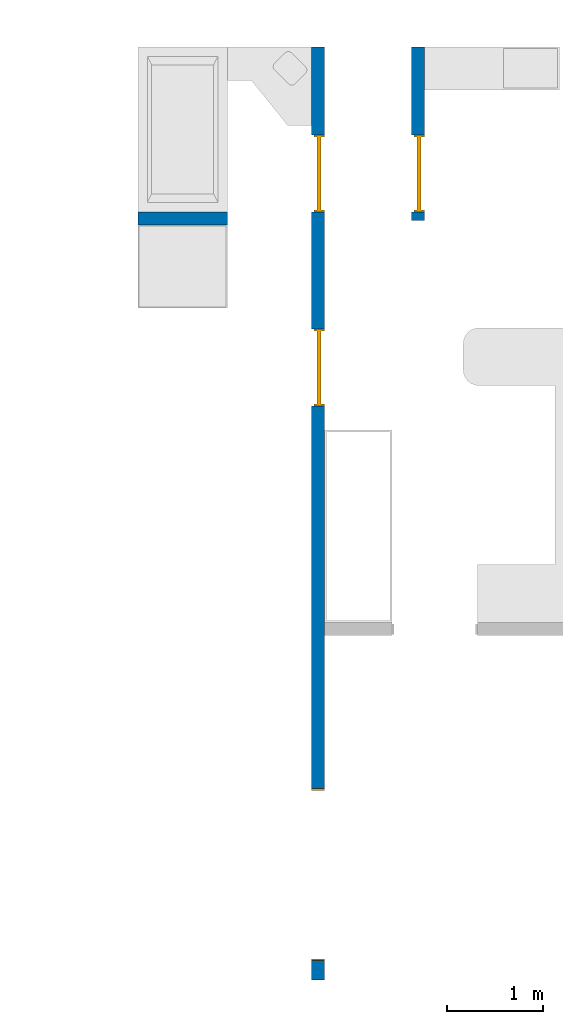
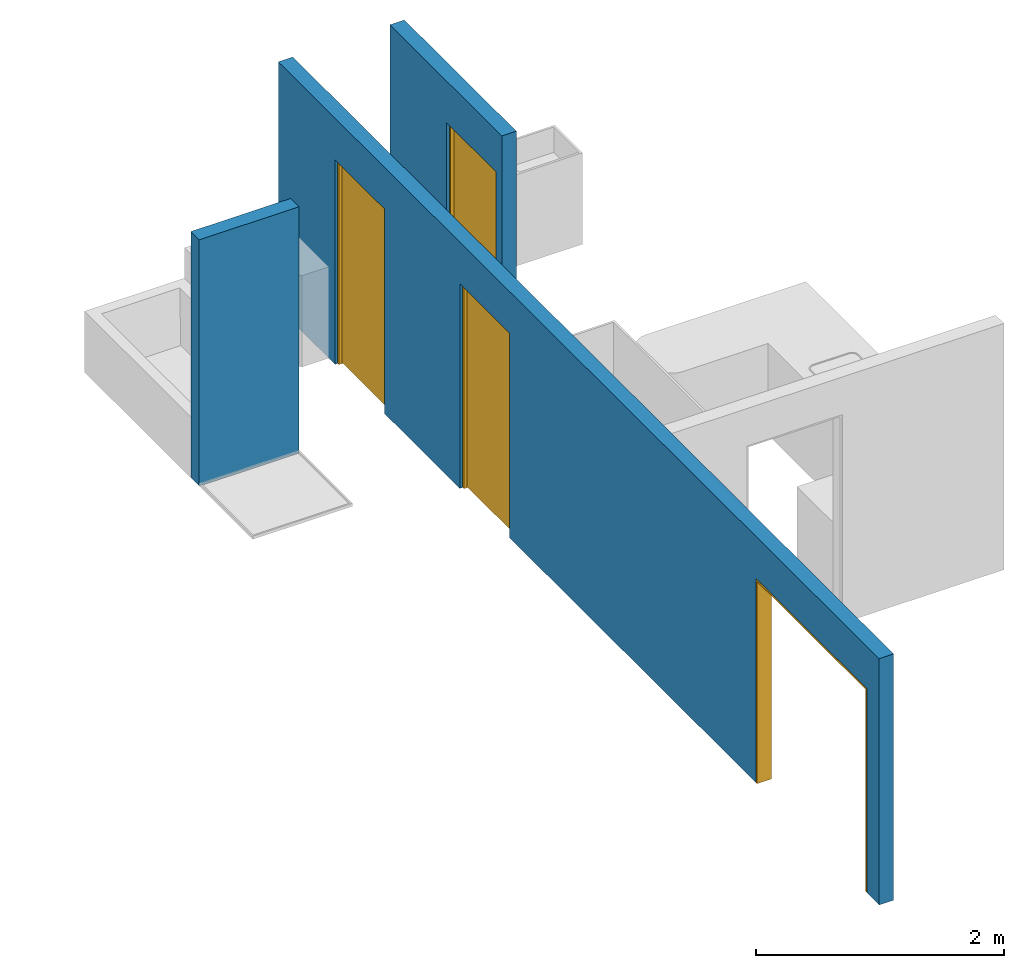
# One storey, part 2 of 6: 4 doors, 3 walls, 4 openings.
"""IFC4 building model written with IfcOpenShell, lengths in millimetres."""

import ifcopenshell
import ifcopenshell.guid

model = None  # the IFC model being written
_history = None  # IfcOwnerHistory: only IFC2X3 demands one
_inside = {}  # id of a spatial element -> (the spatial element, [elements in it])
_under = {}  # id of a project, library or spatial element -> (it, [spatial elements below it])
_declared = {}  # id of a project -> (the project, [libraries it declares])
_typed = {}  # id of a type object -> (the type object, [elements of that type])
_made_of = {}  # id of a material, layer set ... -> (it, [elements and type objects made of it])


def new_model(schema):
    """Start an empty IFC model of exactly this schema.

    Asked for "IFC4X3", IfcOpenShell would pick the latest addendum, in which some entities
    have other attributes; the version numbers below select the first issue.
    IFC2X3 requires an IfcOwnerHistory on every rooted entity: one is made here for all.
    """
    global model, _history
    if schema == "IFC4X3":
        model = ifcopenshell.file(schema_version=(4, 3, 0, 0))
    else:
        model = ifcopenshell.file(schema=schema)
    _inside.clear()
    _under.clear()
    _declared.clear()
    _typed.clear()
    _made_of.clear()
    _history = None
    if model.schema == "IFC2X3":
        org = make("IfcOrganization", Name="unknown")
        user = make(
            "IfcPersonAndOrganization",
            ThePerson=make("IfcPerson", FamilyName="unknown"),
            TheOrganization=org,
        )
        app = make(
            "IfcApplication",
            ApplicationDeveloper=org,
            Version="unknown",
            ApplicationFullName="unknown",
            ApplicationIdentifier="unknown",
        )
        _history = make(
            "IfcOwnerHistory",
            OwningUser=user,
            OwningApplication=app,
            ChangeAction="ADDED",
            CreationDate=0,
        )
    return model


def make(cls, **values):
    """One entity of the class cls with the attributes given. An attribute that is None is left unset."""
    return model.create_entity(
        cls, **{name: value for name, value in values.items() if value is not None}
    )


def entity(cls, *values):
    """Any entity or typed value of the class cls, its attributes in the order of the schema. None: left unset."""
    e = model.create_entity(cls)
    for i, value in enumerate(values):
        if value is not None:
            e[i] = value
    return e


def rooted(cls, **values):
    """An entity with a GlobalId (a new one), such as an element, a storey or a relation."""
    return make(cls, GlobalId=ifcopenshell.guid.new(), OwnerHistory=_history, **values)


def si_unit(unit_type, name, prefix=None):
    """IfcSIUnit, for example si_unit("LENGTHUNIT", "METRE", prefix="MILLI")."""
    return make("IfcSIUnit", UnitType=unit_type, Prefix=prefix, Name=name)


def converted_unit(unit_type, name, factor, base, dimensions=None, offset=None):
    """IfcConversionBasedUnit, such as the inch: factor (a typed value) times the base unit."""
    return make(
        "IfcConversionBasedUnit"
        if offset is None
        else "IfcConversionBasedUnitWithOffset",
        ConversionOffset=offset,
        Dimensions=None
        if dimensions is None
        else entity("IfcDimensionalExponents", *dimensions),
        UnitType=unit_type,
        Name=name,
        ConversionFactor=make(
            "IfcMeasureWithUnit", ValueComponent=factor, UnitComponent=base
        ),
    )


def assignment(units):
    """IfcUnitAssignment: the units of a project."""
    return None if units is None else make("IfcUnitAssignment", Units=units)


def point(xyz):
    """IfcCartesianPoint."""
    return None if xyz is None else make("IfcCartesianPoint", Coordinates=xyz)


def direction(xyz):
    """IfcDirection."""
    return None if xyz is None else make("IfcDirection", DirectionRatios=xyz)


def frame(location, z_axis=None, x_axis=None):
    """IfcAxis2Placement3D, a coordinate frame: its origin and axes. An axis left out is left unset."""
    return make(
        "IfcAxis2Placement3D",
        Location=point(location),
        Axis=direction(z_axis),
        RefDirection=direction(x_axis),
    )


def frame_2d(location, x_axis=None):
    """IfcAxis2Placement2D, a coordinate frame in the plane: its origin and x axis."""
    return make(
        "IfcAxis2Placement2D", Location=point(location), RefDirection=direction(x_axis)
    )


def origin_with_axes():
    """The frame at (0, 0, 0) with the z axis (0, 0, 1) and the x axis (1, 0, 0) written out."""
    return frame((0.0, 0.0, 0.0), z_axis=(0.0, 0.0, 1.0), x_axis=(1.0, 0.0, 0.0))


def origin_2d_with_axis():
    """The frame at (0, 0) in the plane with the x axis (1, 0) written out."""
    return frame_2d((0.0, 0.0), x_axis=(1.0, 0.0))


def place(relative_to, where):
    """IfcLocalPlacement: puts the frame where relative to a parent placement (None: the world)."""
    return make(
        "IfcLocalPlacement", PlacementRelTo=relative_to, RelativePlacement=where
    )


def context(
    kind, dimensions, precision=None, world=None, true_north=None, identifier=None
):
    """IfcGeometricRepresentationContext, for example the 3D "Model" context."""
    return make(
        "IfcGeometricRepresentationContext",
        ContextIdentifier=identifier,
        ContextType=kind,
        CoordinateSpaceDimension=dimensions,
        Precision=precision,
        WorldCoordinateSystem=world,
        TrueNorth=true_north,
    )


def subcontext(parent, identifier, kind, view, scale=None):
    """IfcGeometricRepresentationSubContext, for example "Body" below "Model"."""
    return make(
        "IfcGeometricRepresentationSubContext",
        ContextIdentifier=identifier,
        ContextType=kind,
        ParentContext=parent,
        TargetScale=scale,
        TargetView=view,
    )


def project(units=None, contexts=None):
    """IfcProject with its units and contexts."""
    return rooted(
        "IfcProject",
        Name="project",
        RepresentationContexts=contexts,
        UnitsInContext=assignment(units),
    )


def spatial(cls, under=None, at=None, **own):
    """A site, building, storey or space (cls), placed at a placement, below another one or the project."""
    s = rooted(cls, ObjectPlacement=at, **own)
    if under is not None:
        _under.setdefault(under.id(), (under, []))[1].append(s)
    return s


def point_list(points):
    """IfcCartesianPointList2D or 3D."""
    cls = (
        "IfcCartesianPointList2D" if len(points[0]) == 2 else "IfcCartesianPointList3D"
    )
    return make(cls, CoordList=points)


def line(*indices):
    """IfcLineIndex: a straight run through numbered points of an indexed curve."""
    return model.create_entity("IfcLineIndex", indices)


def indexed_curve(points, segments=None, self_intersect=None):
    """IfcIndexedPolyCurve: lines and arcs through numbered points (the first is 1)."""
    return make(
        "IfcIndexedPolyCurve",
        Points=point_list(points),
        Segments=segments,
        SelfIntersect=self_intersect,
    )


def outline(outer, holes=None, kind="AREA"):
    """IfcArbitraryClosedProfileDef: a profile drawn as a closed curve; with holes, ...WithVoids."""
    if holes is None:
        return make("IfcArbitraryClosedProfileDef", ProfileType=kind, OuterCurve=outer)
    return make(
        "IfcArbitraryProfileDefWithVoids",
        ProfileType=kind,
        OuterCurve=outer,
        InnerCurves=holes,
    )


def extrude(swept, where, along, depth):
    """IfcExtrudedAreaSolid: the profile swept, set in the frame where, extruded along a direction by depth."""
    return make(
        "IfcExtrudedAreaSolid",
        SweptArea=swept,
        Position=where,
        ExtrudedDirection=direction(along),
        Depth=depth,
    )


def polygons(points, faces, closed=None, point_numbers=None):
    """IfcPolygonalFaceSet: a face is its outer loop, then its inner loops; points numbered from 1."""
    made = []
    for loops in faces:
        if len(loops) == 1:
            made.append(make("IfcIndexedPolygonalFace", CoordIndex=loops[0]))
        else:
            made.append(
                make(
                    "IfcIndexedPolygonalFaceWithVoids",
                    CoordIndex=loops[0],
                    InnerCoordIndices=loops[1:],
                )
            )
    return make(
        "IfcPolygonalFaceSet",
        Coordinates=point_list(points),
        Closed=closed,
        Faces=made,
        PnIndex=point_numbers,
    )


def shape(context_of_items, identifier, shape_type, items):
    """IfcShapeRepresentation: the items that make up one representation, for example the "Body"."""
    return make(
        "IfcShapeRepresentation",
        ContextOfItems=context_of_items,
        RepresentationIdentifier=identifier,
        RepresentationType=shape_type,
        Items=items,
    )


def source(mapping_origin, context_of_items, identifier, shape_type, items):
    """IfcRepresentationMap: a shape defined once, which mapped items show again and again."""
    return make(
        "IfcRepresentationMap",
        MappingOrigin=mapping_origin,
        MappedRepresentation=shape(context_of_items, identifier, shape_type, items),
    )


def transform(
    local_origin,
    x_axis=None,
    y_axis=None,
    z_axis=None,
    scale=None,
    scale2=None,
    scale3=None,
    uniform=True,
):
    """IfcCartesianTransformationOperator3D, or its non-uniform kind. x_axis, y_axis, z_axis: its Axis1, 2, 3."""
    if uniform:
        return make(
            "IfcCartesianTransformationOperator3D",
            Axis1=direction(x_axis),
            Axis2=direction(y_axis),
            LocalOrigin=point(local_origin),
            Scale=scale,
            Axis3=direction(z_axis),
        )
    return make(
        "IfcCartesianTransformationOperator3DnonUniform",
        Axis1=direction(x_axis),
        Axis2=direction(y_axis),
        LocalOrigin=point(local_origin),
        Scale=scale,
        Axis3=direction(z_axis),
        Scale2=scale2,
        Scale3=scale3,
    )


def mapped(mapping_source, mapping_target):
    """IfcMappedItem: shows the shape of a source again, moved by a transform."""
    return make(
        "IfcMappedItem", MappingSource=mapping_source, MappingTarget=mapping_target
    )


def material(Name=None, Category=None):
    """IfcMaterial."""
    return make("IfcMaterial", Name=Name, Category=Category)


def layer(
    of_material, thickness, ventilated=None, Name=None, Category=None, Priority=None
):
    """IfcMaterialLayer: one layer of a wall or slab, of a material (None: an air gap)."""
    return make(
        "IfcMaterialLayer",
        Material=of_material,
        LayerThickness=thickness,
        IsVentilated=ventilated,
        Name=Name,
        Category=Category,
        Priority=Priority,
    )


def layer_set(layers, Name=None):
    """IfcMaterialLayerSet."""
    return make("IfcMaterialLayerSet", MaterialLayers=layers, LayerSetName=Name)


def layer_usage(for_layer_set, set_direction, sense, offset, extent=None):
    """IfcMaterialLayerSetUsage: how a layer set lies in its element."""
    return make(
        "IfcMaterialLayerSetUsage",
        ForLayerSet=for_layer_set,
        LayerSetDirection=set_direction,
        DirectionSense=sense,
        OffsetFromReferenceLine=offset,
        ReferenceExtent=extent,
    )


def made_of(thing, what):
    """Note that an element or type object is made of a material, layer set ...; save() writes the relation."""
    if what is not None:
        _made_of.setdefault(what.id(), (what, []))[1].append(thing)
    return thing


def type_object(cls, material=None, **own):
    """A type object (cls), such as IfcWallType, which elements share."""
    return made_of(rooted(cls, **own), material)


def type_shapes(of_type, sources):
    """Give a type object the sources (RepresentationMaps) that its elements show as mapped items."""
    of_type.RepresentationMaps = sources


def element(
    cls,
    number,
    at=None,
    inside=None,
    cuts=None,
    type_object=None,
    material=None,
    context=None,
    identifier="Body",
    shape_type=None,
    held_by="IfcProductDefinitionShape",
    body=None,
    shapes=None,
    **own,
):
    """One element of the class cls, such as IfcWall. Its Tag is "e" and its number.

    at: its placement. inside: the storey or other place that contains it. cuts: it is an
    opening in that element (IfcRelVoidsElement). A single representation is given by context,
    identifier, shape_type and body (its items); several are given by shapes. held_by: the class
    of the entity that holds the representations. save() writes the other relations.
    """
    e = rooted(cls, Tag="e%d" % number, ObjectPlacement=at, **own)
    if body is not None:
        shapes = [shape(context, identifier, shape_type, body)]
    if shapes is not None:
        e.Representation = make(held_by, Representations=shapes)
    if inside is not None:
        _inside.setdefault(inside.id(), (inside, []))[1].append(e)
    if cuts is not None:
        rooted(
            "IfcRelVoidsElement", RelatingBuildingElement=cuts, RelatedOpeningElement=e
        )
    if type_object is not None:
        _typed.setdefault(type_object.id(), (type_object, []))[1].append(e)
    return made_of(e, material)


def fill(opening, filler):
    """IfcRelFillsElement: the door or window that sits in an opening."""
    return rooted(
        "IfcRelFillsElement",
        RelatingOpeningElement=opening,
        RelatedBuildingElement=filler,
    )


def aggregate(whole, parts):
    """IfcRelAggregates: a whole, such as a stair, and the parts it consists of."""
    return rooted("IfcRelAggregates", RelatingObject=whole, RelatedObjects=parts)


def save(model, path):
    """Write the relations noted so far, then the file.

    IfcRelAggregates (storeys below a building ...), IfcRelContainedInSpatialStructure (elements
    in a storey), IfcRelDefinesByType, IfcRelAssociatesMaterial and IfcRelDeclares: one each for
    every whole, place, type object, material and project.
    """
    for whole, parts in _under.values():
        aggregate(whole, parts)
    for where, things in _inside.values():
        rooted(
            "IfcRelContainedInSpatialStructure",
            RelatedElements=things,
            RelatingStructure=where,
        )
    for kind, things in _typed.values():
        rooted("IfcRelDefinesByType", RelatedObjects=things, RelatingType=kind)
    for what, things in _made_of.values():
        rooted("IfcRelAssociatesMaterial", RelatedObjects=things, RelatingMaterial=what)
    for by, libraries in _declared.values():
        rooted("IfcRelDeclares", RelatingContext=by, RelatedDefinitions=libraries)
    model.write(path)


model = new_model("IFC4")

# Units and contexts
model_context = context("Model", 3, precision=1e-05, world=origin_with_axes())
plan_context = context("Plan", 2, precision=1e-05, world=origin_2d_with_axis())
body_context = subcontext(model_context, "Body", "Model", "MODEL_VIEW")
ifc_project = project(units=[si_unit("VOLUMEUNIT", "CUBIC_METRE"), si_unit("LENGTHUNIT", "METRE", prefix="MILLI"), converted_unit("PLANEANGLEUNIT", "degree", entity("IfcReal", 0.0174532925199433), si_unit("PLANEANGLEUNIT", "RADIAN"), dimensions=[0, 0, 0, 0, 0, 0, 0]), si_unit("AREAUNIT", "SQUARE_METRE")], contexts=[model_context, plan_context])

# Site, building, storey
site_placement = place(None, origin_with_axes())
site = spatial("IfcSite", under=ifc_project, at=site_placement)
building_placement = place(site_placement, origin_with_axes())
building = spatial("IfcBuilding", under=site, at=building_placement, Name="Building")
storey_placement = place(building_placement, origin_with_axes())
storey = spatial("IfcBuildingStorey", under=building, at=storey_placement, Name="DEMO")

# Wall, opening, door
ifc_material = material()
ifc_layer = layer(ifc_material, 135.0)
ifc_layer_set = layer_set([ifc_layer])
ifc_layer_usage_1 = layer_usage(ifc_layer_set, "AXIS2", "POSITIVE", 0.0)
wall_type = type_object("IfcWallType", Name="WAL135", PredefinedType="NOTDEFINED", material=ifc_layer_set)
wall_1_placement = place(storey_placement, frame((11019.1202163696, 5461.66706085205, 0.0), z_axis=(0.0, 0.0, 1.0), x_axis=(3.13916473260163e-07, -0.999999999999951, 0.0)))
wall_1 = element("IfcWall", 1, at=wall_1_placement, inside=storey, type_object=wall_type, material=ifc_layer_usage_1, Name="Wall", context=body_context, shape_type="SweptSolid", body=[
    extrude(outline(indexed_curve([(0.0, 0.0), (0.0, 135.0), (1805.00031109354, 135.0), (1805.00031109354, 0.0), (0.0, 0.0)], self_intersect=False)), origin_with_axes(), (0.0, 0.0, 1.0), 2425.00019073486),
])
shared_shape_1 = source(origin_with_axes(), body_context, "Body", "SweptSolid", [
    extrude(outline(indexed_curve([(0.0, 0.0), (800.001098632812, 0.0), (800.001098632812, 2015.00024414062), (0.0, 2015.00024414062)], segments=[line(1, 2, 3, 4, 1)])), frame((-1.78813922957488e-06, -600.0, 0.0), z_axis=(0.0, -1.0, 0.0), x_axis=(1.0, 0.0, 0.0)), (0.0, 0.0, -1.0), 1200.0),
])
opening_1_placement = place(wall_1_placement, frame((915.001869201841, 0.000284435057257282, 0.0), z_axis=(0.0, 0.0, 1.0), x_axis=(1.0, 0.0, 0.0)))
opening_1 = element("IfcOpeningElement", 2, at=opening_1_placement, cuts=wall_1, Name="Opening", PredefinedType="OPENING", context=body_context, shape_type="MappedRepresentation", body=[
    mapped(shared_shape_1, transform((0.0, 0.0, 0.0), x_axis=(1.0, 0.0, 0.0), y_axis=(0.0, 1.0, 0.0), z_axis=(0.0, 0.0, 1.0), scale=1.0)),
])
door_type_1 = type_object("IfcDoorType", OperationType="NOTDEFINED", PredefinedType="DOOR")
shared_shape_2 = source(origin_with_axes(), body_context, "Body", "Tessellation", [
    polygons([(0.000119209282274824, -53.7499732971191, 0.0), (20.0005760192871, -53.7499732971191, 0.0), (0.000119209282274824, -53.75, 1994.99987792969), (20.0005760192871, -53.75, 1994.99987792969), (0.000119209282274824, 56.2500038146973, 0.0), (20.0005760192871, 56.2500076293945, 0.0), (0.000119209282274824, 56.2499351501465, 1994.99987792969), (20.0005760192871, 56.249942779541, 1994.99987792969), (799.999328613281, -53.7499656677246, 1994.99987792969), (-0.0017881392268464, -53.75, 1994.99987792969), (799.999328613281, -53.7499656677246, 2015.00024414062), (799.999328613281, 56.2499809265137, 1994.99987792969), (-0.0017881392268464, 56.2499351501465, 1994.99987792969), (799.999328613281, 56.2499809265137, 2015.00024414062), (-0.0017881392268464, 56.2499351501465, 2014.99975585938), (-0.0017881392268464, -53.75, 2014.99975585938), (779.996948242188, -53.7499656677246, 0.0), (779.996948242188, -53.7499923706055, 1994.99987792969), (799.999328613281, -53.7499656677246, 0.0), (779.996948242188, 56.2499771118164, 0.0), (779.996948242188, 56.249942779541, 1994.99987792969), (799.999328613281, 56.2499809265137, 0.0), (799.999328613281, 56.2499465942383, 1994.99987792969), (799.999328613281, -53.7499923706055, 1994.99987792969), (779.998840332031, -23.7499713897705, 1994.99987792969), (779.996948242188, -23.749942779541, 9.99998950958252), (19.9986686706543, -23.749979019165, 1994.99987792969), (779.998840332031, 16.2500343322754, 1994.99987792969), (779.996948242188, 16.2500343322754, 9.99998950958252), (19.9986686706543, 16.2500305175781, 1994.99987792969), (19.9967613220215, 16.2500305175781, 9.99998950958252), (19.9967613220215, -23.7499465942383, 9.99998950958252)], [[[1, 2, 4, 3]], [[3, 4, 8, 7]], [[7, 8, 6, 5]], [[5, 6, 2, 1]], [[3, 7, 5, 1]], [[8, 4, 2, 6]], [[10, 13, 12, 9]], [[9, 11, 16, 10]], [[12, 14, 11, 9]], [[13, 15, 14, 12]], [[15, 16, 11, 14]], [[10, 16, 15, 13]], [[18, 21, 20, 17]], [[17, 19, 24, 18]], [[20, 22, 19, 17]], [[21, 23, 22, 20]], [[23, 24, 19, 22]], [[18, 24, 23, 21]], [[26, 29, 28, 25]], [[25, 27, 32, 26]], [[28, 30, 27, 25]], [[29, 31, 30, 28]], [[31, 32, 27, 30]], [[26, 32, 31, 29]]], closed=True),
])
type_shapes(door_type_1, [shared_shape_2])
door_1_placement = place(opening_1_placement, frame((0.00145523266148473, 78.7509923562393, 0.0), z_axis=(0.0, 0.0, 1.0), x_axis=(0.999999999999886, -4.76837158203095e-07, 0.0)))
door_1 = element("IfcDoor", 3, at=door_1_placement, inside=storey, type_object=door_type_1, Name="Door", context=body_context, shape_type="MappedRepresentation", body=[
    mapped(shared_shape_2, transform((0.0, 0.0, 0.0), x_axis=(1.0, 0.0, 0.0), y_axis=(0.0, 1.0, 0.0), z_axis=(0.0, 0.0, 1.0), scale=1.0)),
])
fill(opening_1, door_1)

# Wall
ifc_layer_usage_2 = layer_usage(ifc_layer_set, "AXIS2", "POSITIVE", 0.0)
wall_2_placement = place(storey_placement, frame((8174.11994934082, 3611.6669178009, 0.0), z_axis=(0.0, 0.0, 1.0), x_axis=(0.999999999999972, 2.38418579101556e-07, 0.0)))
element("IfcWall", 4, at=wall_2_placement, inside=storey, type_object=wall_type, material=ifc_layer_usage_2, Name="Wall", context=body_context, shape_type="SweptSolid", body=[
    extrude(outline(indexed_curve([(0.0, 0.0), (0.0, 135.0), (930.000316660868, 135.0), (930.000316660868, 0.0), (0.0, 0.0)], self_intersect=False)), origin_with_axes(), (0.0, 0.0, 1.0), 2425.00019073486),
])

# Wall, openings, doors
ifc_layer_usage_3 = layer_usage(ifc_layer_set, "AXIS2", "POSITIVE", 0.0)
wall_3_placement = place(storey_placement, frame((9979.12120819092, 5461.66801452637, 0.0), z_axis=(0.0, 0.0, 1.0), x_axis=(3.13916473260163e-07, -0.999999999999951, 0.0)))
wall_3 = element("IfcWall", 5, at=wall_3_placement, inside=storey, type_object=wall_type, material=ifc_layer_usage_3, Name="Wall", context=body_context, shape_type="SweptSolid", body=[
    extrude(outline(indexed_curve([(0.0, 0.0), (0.0, 135.0), (9695.0004828675, 135.0), (9695.0004828675, 0.0), (0.0, 0.0)], self_intersect=False)), origin_with_axes(), (0.0, 0.0, 1.0), 2425.00019073486),
])
opening_2_placement = place(wall_3_placement, frame((2930.00319686536, 78.7500654126747, 0.0), z_axis=(0.0, 0.0, 1.0), x_axis=(1.0, 0.0, 0.0)))
opening_2 = element("IfcOpeningElement", 6, at=opening_2_placement, cuts=wall_3, Name="Opening", PredefinedType="OPENING", context=body_context, shape_type="MappedRepresentation", body=[
    mapped(shared_shape_1, transform((0.0, 0.0, 0.0), x_axis=(1.0, 0.0, 0.0), y_axis=(0.0, 1.0, 0.0), z_axis=(0.0, 0.0, 1.0), scale=1.0)),
])
opening_3_placement = place(wall_3_placement, frame((915.000915527553, 0.000358941234512855, 0.0), z_axis=(0.0, 0.0, 1.0), x_axis=(1.0, 0.0, 0.0)))
opening_3 = element("IfcOpeningElement", 7, at=opening_3_placement, cuts=wall_3, Name="Opening", PredefinedType="OPENING", context=body_context, shape_type="MappedRepresentation", body=[
    mapped(shared_shape_1, transform((0.0, 0.0, 0.0), x_axis=(1.0, 0.0, 0.0), y_axis=(0.0, 1.0, 0.0), z_axis=(0.0, 0.0, 1.0), scale=1.0)),
])
shared_shape_3 = source(origin_with_axes(), body_context, "Body", "SweptSolid", [
    extrude(outline(indexed_curve([(0.0, 0.0), (1790.00024414062, 0.0), (1790.00024414062, 2009.99987792969), (0.0, 2009.99987792969)], segments=[line(1, 2, 3, 4, 1)])), frame((0.0, -600.0, 0.0), z_axis=(0.0, -1.0, 0.0), x_axis=(1.0, 0.0, 0.0)), (0.0, 0.0, -1.0), 1200.0),
])
opening_4_placement = place(wall_3_placement, frame((7705.00091632267, 100.000718891784, 0.0), z_axis=(0.0, 0.0, 1.0), x_axis=(1.0, 0.0, 0.0)))
opening_4 = element("IfcOpeningElement", 8, at=opening_4_placement, cuts=wall_3, PredefinedType="OPENING", context=body_context, shape_type="MappedRepresentation", body=[
    mapped(shared_shape_3, transform((0.0, 0.0, 0.0), x_axis=(1.0, 0.0, 0.0), y_axis=(0.0, 1.0, 0.0), z_axis=(0.0, 0.0, 1.0), scale=1.0)),
])
door_2_placement = place(opening_2_placement, frame((0.00047089180021942, 0.000578836786502279, 0.0), z_axis=(0.0, 0.0, 1.0), x_axis=(0.999999999999886, -4.76837158203095e-07, 0.0)))
door_2 = element("IfcDoor", 9, at=door_2_placement, inside=storey, type_object=door_type_1, Name="Door", context=body_context, shape_type="MappedRepresentation", body=[
    mapped(shared_shape_2, transform((0.0, 0.0, 0.0), x_axis=(1.0, 0.0, 0.0), y_axis=(0.0, 1.0, 0.0), z_axis=(0.0, 0.0, 1.0), scale=1.0)),
])
fill(opening_2, door_2)
door_3_placement = place(opening_3_placement, frame((0.00145523263661573, 78.7509178503303, 0.0), z_axis=(0.0, 0.0, 1.0), x_axis=(0.999999999999886, -4.76837158203095e-07, 0.0)))
door_3 = element("IfcDoor", 10, at=door_3_placement, inside=storey, type_object=door_type_1, Name="Door", context=body_context, shape_type="MappedRepresentation", body=[
    mapped(shared_shape_2, transform((0.0, 0.0, 0.0), x_axis=(1.0, 0.0, 0.0), y_axis=(0.0, 1.0, 0.0), z_axis=(0.0, 0.0, 1.0), scale=1.0)),
])
fill(opening_3, door_3)
door_type_2 = type_object("IfcDoorType", OperationType="NOTDEFINED", PredefinedType="DOOR")
shared_shape_4 = source(origin_with_axes(), body_context, "Body", "Tessellation", [
    polygons([(0.0, -99.9999923706055, 1989.99987792969), (0.0, -99.9999923706055, 2009.99987792969), (0.0, 35.0, 1989.99987792969), (0.0, 35.0, 2009.99987792969), (1789.99987792969, -99.9999923706055, 1989.99987792969), (1789.99987792969, -99.9999923706055, 2009.99987792969), (1789.99987792969, 35.0, 1989.99987792969), (1789.99987792969, 35.0, 2009.99987792969), (0.0, -99.9999923706055, 0.0), (0.0, -99.9999923706055, 1989.99963378906), (0.0, 35.0, 0.0), (0.0, 35.0, 1989.99963378906), (19.999979019165, -99.9999923706055, 0.0), (19.999979019165, -99.9999923706055, 1989.99963378906), (19.999979019165, 35.0, 0.0), (19.999979019165, 35.0, 1989.99963378906), (1769.99987792969, -99.9999923706055, 0.0), (1769.99987792969, -99.9999923706055, 1989.99963378906), (1769.99987792969, 35.0, 0.0), (1769.99987792969, 35.0, 1989.99963378906), (1790.00036621094, -99.9999923706055, 0.0), (1790.00036621094, -99.9999923706055, 1989.99963378906), (1790.00036621094, 35.0, 0.0), (1790.00036621094, 35.0, 1989.99963378906)], [[[1, 2, 4, 3]], [[3, 4, 8, 7]], [[7, 8, 6, 5]], [[5, 6, 2, 1]], [[3, 7, 5, 1]], [[8, 4, 2, 6]], [[9, 10, 12, 11]], [[11, 12, 16, 15]], [[15, 16, 14, 13]], [[13, 14, 10, 9]], [[11, 15, 13, 9]], [[16, 12, 10, 14]], [[17, 18, 20, 19]], [[19, 20, 24, 23]], [[23, 24, 22, 21]], [[21, 22, 18, 17]], [[19, 23, 21, 17]], [[24, 20, 18, 22]]], closed=True),
])
type_shapes(door_type_2, [shared_shape_4])
door_4_placement = place(opening_4_placement, frame((-0.000245968889256432, -0.000848800057795529, 0.0), z_axis=(0.0, 0.0, 1.0), x_axis=(1.0, 5.29395592033938e-23, 0.0)))
door_4 = element("IfcDoor", 11, at=door_4_placement, inside=storey, type_object=door_type_2, Name="Door", context=body_context, shape_type="MappedRepresentation", body=[
    mapped(shared_shape_4, transform((0.0, 0.0, 0.0), x_axis=(1.0, 0.0, 0.0), y_axis=(0.0, 1.0, 0.0), z_axis=(0.0, 0.0, 1.0), scale=1.0)),
])
fill(opening_4, door_4)

save(model, "model.ifc")
